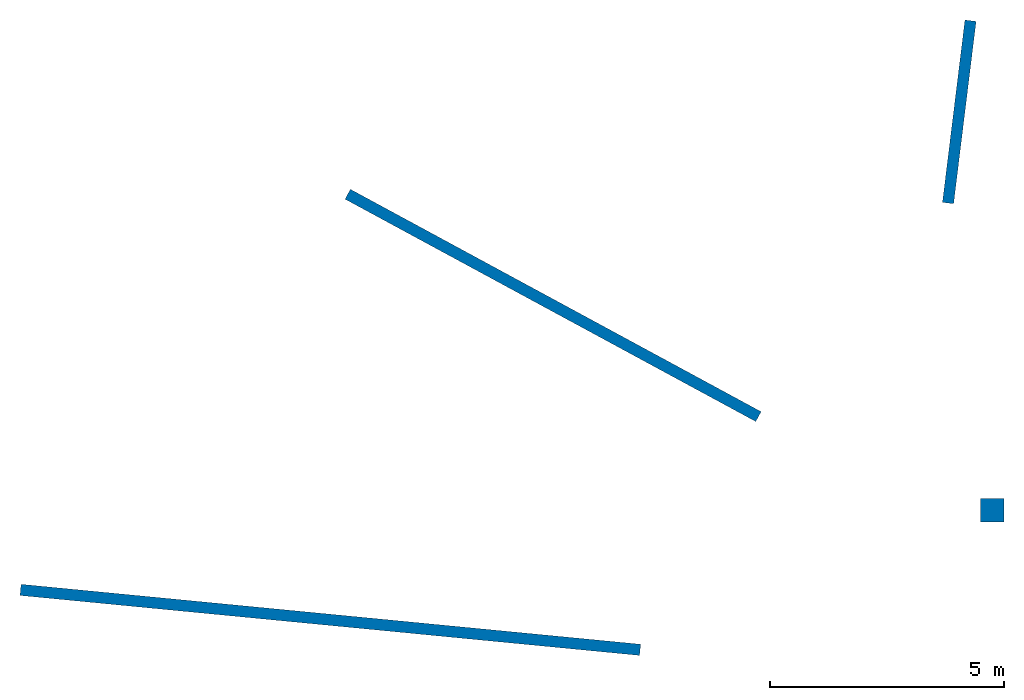
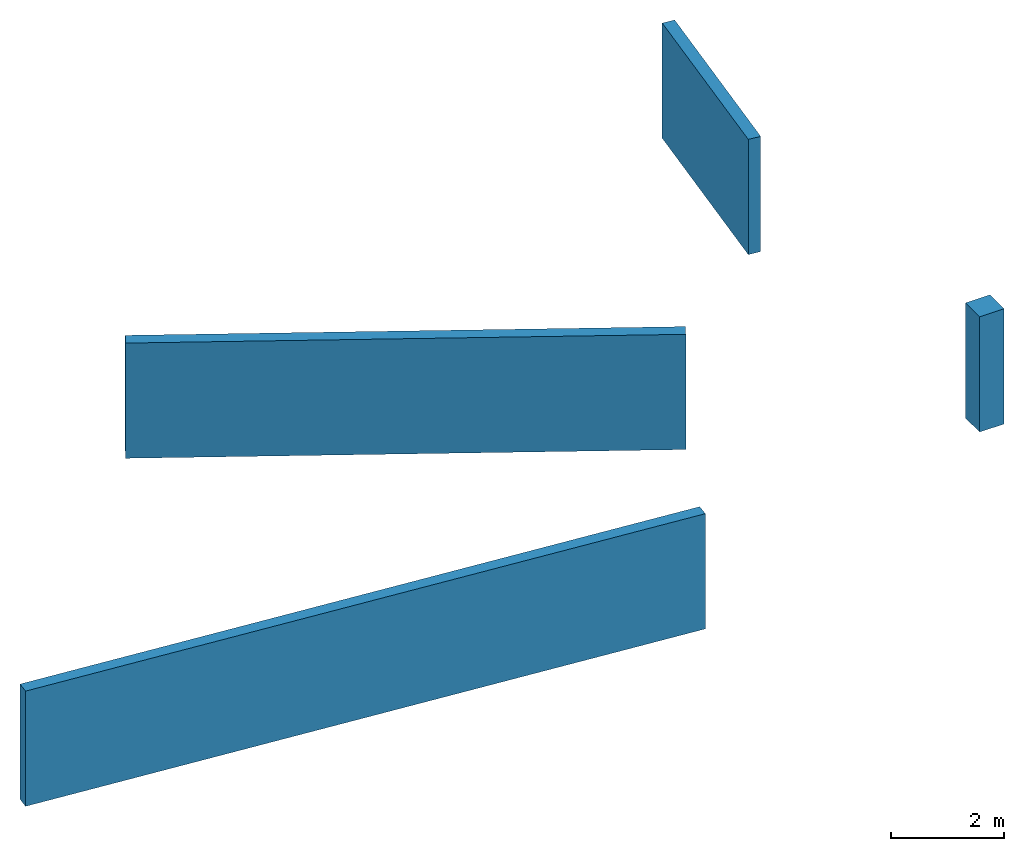
# Not in any storey: 3 walls, 1 column.
"""IFC2X3 model written with IfcOpenShell, lengths in metres."""

from ifc_helpers import new_model, entity, si_unit, converted_unit, frame, frame_2d, origin, origin_with_axes, place, context, subcontext, project, spatial, rectangle, extrude, material, layer, layer_set, layer_usage, element, save


model = new_model("IFC2X3")

# Units and contexts
model_context = context("Model", 3, precision=1e-05, world=origin())
body_context = subcontext(model_context, "Body", "Model", "MODEL_VIEW")
ifc_project = project(units=[si_unit("LENGTHUNIT", "METRE"), converted_unit("PLANEANGLEUNIT", "DEGREE", entity("IfcPlaneAngleMeasure", 0.0174532925199433), si_unit("PLANEANGLEUNIT", "RADIAN"), dimensions=[0, 0, 0, 0, 0, 0, 0]), si_unit("AREAUNIT", "SQUARE_METRE"), si_unit("VOLUMEUNIT", "CUBIC_METRE")], contexts=[model_context])

# Site
site_placement = place(None, origin())
site = spatial("IfcSite", under=ifc_project, at=site_placement, CompositionType="ELEMENT")

# Column
ifc_material_1 = material(Name="concrete")
column_placement = place(site_placement, frame((19.75815739008651, 4.813321248196222, 0.0), z_axis=(0.0, 0.0, 1.0), x_axis=(1.0, 0.0, 0.0)))
element("IfcColumn", 1, at=column_placement, inside=site, material=ifc_material_1, context=body_context, shape_type="SweptSolid", body=[
    extrude(rectangle(XDim=0.5, YDim=0.5, at=frame_2d((0.25, 0.25), x_axis=(1.0, 0.0))), origin_with_axes(), (0.0, 0.0, 1.0), 2.5),
])

# Walls
ifc_material_2 = material(Name="concrete")
ifc_layer_1 = layer(ifc_material_2, 0.2399999999999896)
ifc_layer_set_1 = layer_set([ifc_layer_1])
ifc_layer_usage_1 = layer_usage(ifc_layer_set_1, "AXIS2", "POSITIVE", 0.0)
wall_1_placement = place(site_placement, frame((6.206044640834949, 11.69909870892209, 0.0), z_axis=(0.0, 0.0, 1.0), x_axis=(0.8793533558062362, -0.4761697970601571, 0.0)))
element("IfcWallStandardCase", 2, at=wall_1_placement, inside=site, material=ifc_layer_usage_1, context=body_context, shape_type="SweptSolid", body=[
    extrude(rectangle(XDim=9.96, YDim=0.2399999999999896, at=frame_2d((4.98, 0.1199999999999948), x_axis=(1.0, 0.0))), origin_with_axes(), (0.0, 0.0, 1.0), 2.5),
])
ifc_material_3 = material(Name="concrete")
ifc_layer_2 = layer(ifc_material_3, 0.240000000000001)
ifc_layer_set_2 = layer_set([ifc_layer_2])
ifc_layer_usage_2 = layer_usage(ifc_layer_set_2, "AXIS2", "POSITIVE", 0.0)
wall_2_placement = place(site_placement, frame((19.18418268608335, 11.60153614039584, 0.0), z_axis=(0.0, 0.0, 1.0), x_axis=(0.1223300974157738, 0.9924894695996764, 0.0)))
element("IfcWallStandardCase", 3, at=wall_2_placement, inside=site, material=ifc_layer_usage_2, context=body_context, shape_type="SweptSolid", body=[
    extrude(rectangle(XDim=3.918078376707022, YDim=0.240000000000001, at=frame_2d((1.959039188353511, 0.1200000000000005), x_axis=(1.0, 0.0))), origin_with_axes(), (0.0, 0.0, 1.0), 2.5),
])
ifc_material_4 = material(Name="concrete")
ifc_layer_3 = layer(ifc_material_4, 0.2399999999999993)
ifc_layer_set_3 = layer_set([ifc_layer_3])
ifc_layer_usage_3 = layer_usage(ifc_layer_set_3, "AXIS2", "POSITIVE", 0.0)
wall_3_placement = place(site_placement, frame((-0.725454765088547, 3.248040860447919, 0.0), z_axis=(0.0, 0.0, 1.0), x_axis=(0.9953473041029298, -0.09635218842885564, 0.0)))
element("IfcWallStandardCase", 4, at=wall_3_placement, inside=site, material=ifc_layer_usage_3, context=body_context, shape_type="SweptSolid", body=[
    extrude(rectangle(XDim=13.27413232718776, YDim=0.2399999999999993, at=frame_2d((6.637066163593881, 0.1199999999999997), x_axis=(1.0, 0.0))), origin_with_axes(), (0.0, 0.0, 1.0), 2.5),
])

save(model, "model.ifc")
